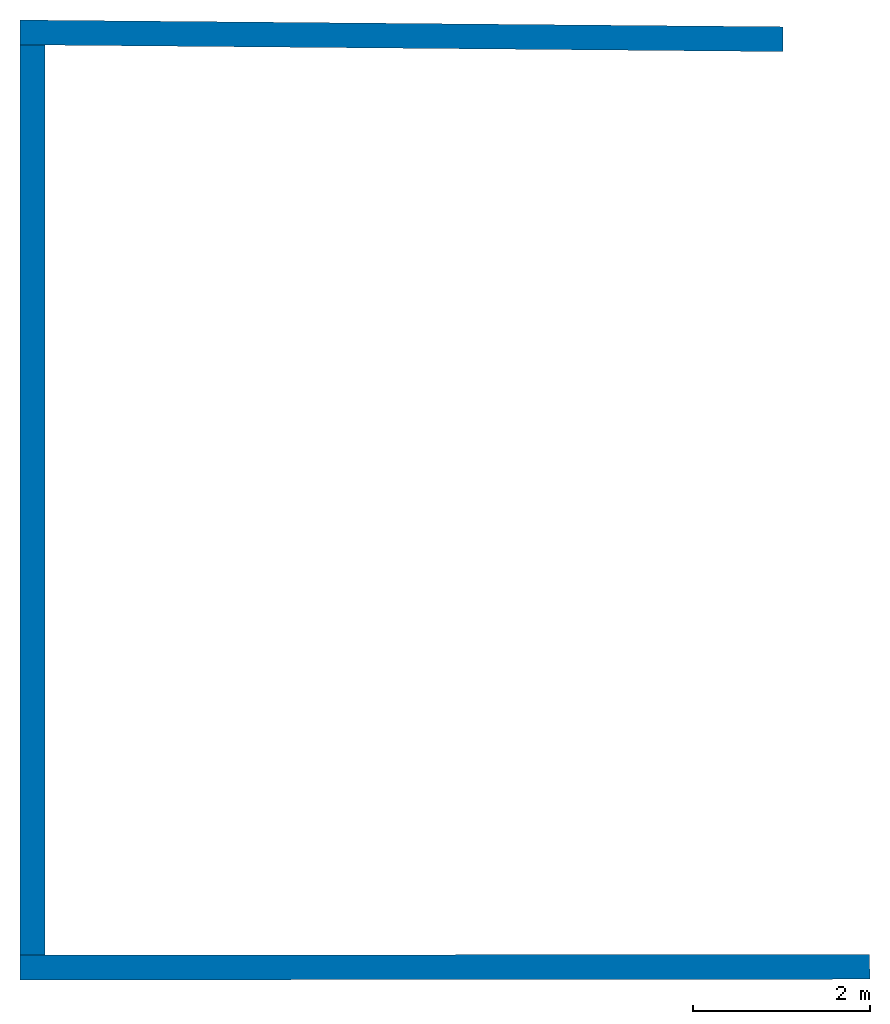
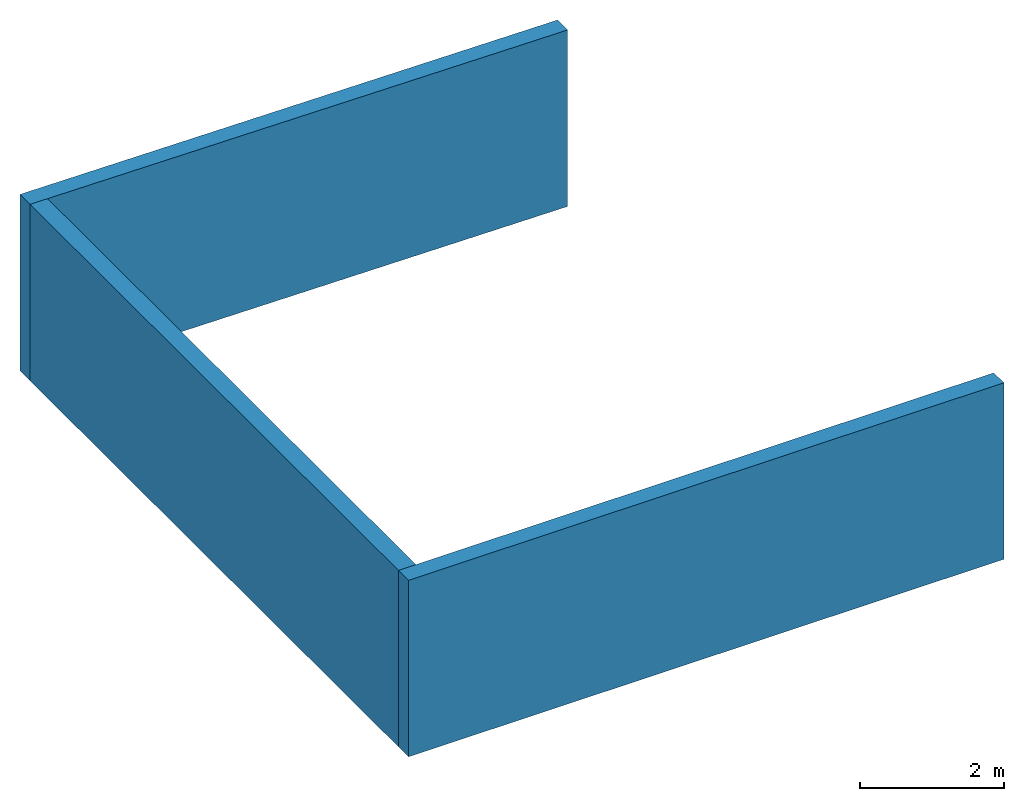
# One storey: 3 walls.
"""IFC4 building model written with IfcOpenShell, lengths in metres."""

from ifc_helpers import new_model, entity, si_unit, converted_unit, frame, frame_2d, origin_with_axes, place, context, subcontext, project, spatial, indexed_curve, outline, extrude, clip, halfspace, material, layer, layer_set, layer_usage, type_object, element, save


model = new_model("IFC4")

# Units and contexts
model_context = context("Model", 3, precision=1e-05, world=origin_with_axes())
plan_context = context("Plan", 2, precision=1e-05, world=frame_2d((0.0, 0.0, 0.0), x_axis=(1.0, 0.0, 0.0)))
body_context = subcontext(model_context, "Body", "Model", "MODEL_VIEW")
ifc_project = project(units=[converted_unit("PLANEANGLEUNIT", "degree", entity("IfcReal", 0.0174532925199433), si_unit("PLANEANGLEUNIT", "RADIAN"), dimensions=[0, 0, 0, 0, 0, 0, 0]), si_unit("AREAUNIT", "SQUARE_METRE"), si_unit("VOLUMEUNIT", "CUBIC_METRE"), si_unit("LENGTHUNIT", "METRE")], contexts=[model_context, plan_context])

# Site, building, storey
site_placement = place(None, origin_with_axes())
site = spatial("IfcSite", under=ifc_project, at=site_placement)
building_placement = place(site_placement, origin_with_axes())
building = spatial("IfcBuilding", under=site, at=building_placement, Name="Building")
storey_placement = place(building_placement, origin_with_axes())
storey = spatial("IfcBuildingStorey", under=building, at=storey_placement, Name="Storey")

# Walls
ifc_material = material(Name="aussenwand_280_material")
ifc_layer = layer(ifc_material, 0.280000001192093)
ifc_layer_set = layer_set([ifc_layer])
ifc_layer_usage_1 = layer_usage(ifc_layer_set, "AXIS2", "POSITIVE", 0.0)
wall_type = type_object("IfcWallType", Name="aussenwand_280", PredefinedType="STANDARD", material=ifc_layer_set)
wall_1_placement = place(storey_placement, frame((9.47131252288818, 11.6613798141479, 0.0), z_axis=(0.0, 0.0, 1.0), x_axis=(-0.999960541725159, 0.00888374913483858, 0.0)))
element("IfcWall", 1, at=wall_1_placement, inside=storey, type_object=wall_type, material=ifc_layer_usage_1, Name="Wall", PredefinedType="NOTDEFINED", context=body_context, shape_type="Clipping", body=[
    clip(clip(extrude(outline(indexed_curve([(0.0, 0.0), (0.0, 0.280000001192093), (8.87914620865895, 0.280000001192093), (8.87914620865895, 0.0), (0.0, 0.0)], self_intersect=False)), origin_with_axes(), (0.0, 0.0, 1.0), 3.0), halfspace(frame((0.282497853040695, 4.32133674621582e-07, 0.0), z_axis=(-0.839997529983521, -0.00746262166649103, 0.0), x_axis=(-0.0024875404778868, 0.279999166727066, 0.0)), False)), halfspace(frame((8.87914562225342, 4.97326254844666e-07, 0.0), z_axis=(0.839997529983521, 0.00746244285255671, 0.0), x_axis=(-0.00248748087324202, 0.279999166727066, 0.0)), False)),
])
ifc_layer_usage_2 = layer_usage(ifc_layer_set, "AXIS2", "POSITIVE", 0.0)
wall_2_placement = place(storey_placement, frame((0.592516601085663, 0.922550857067108, 0.0), z_axis=(0.0, 0.0, 1.0), x_axis=(0.999999582767487, 0.000923240790143609, 0.0)))
element("IfcWall", 2, at=wall_2_placement, inside=storey, type_object=wall_type, material=ifc_layer_usage_2, Name="Wall", PredefinedType="NOTDEFINED", context=body_context, shape_type="Clipping", body=[
    clip(clip(extrude(outline(indexed_curve([(0.0, 0.0), (0.0, 0.280000001192093), (17.7553288631672, 0.280000001192093), (17.7553288631672, 0.0), (0.0, 0.0)], self_intersect=False)), origin_with_axes(), (0.0, 0.0, 1.0), 3.0), halfspace(frame((-1.38534232974052e-08, -4.3713953346014e-08, 0.0), z_axis=(-0.839999914169312, 0.000775522494222969, 0.0), x_axis=(0.000258507498074323, 0.279999971389771, 0.0)), False)), halfspace(frame((9.57749176025391, 3.81842255592346e-08, 0.0), z_axis=(0.839999616146088, 0.0143678784370422, 0.0), x_axis=(-0.00478929281234741, 0.279999852180481, 0.0)), False)),
])
ifc_layer_usage_3 = layer_usage(ifc_layer_set, "AXIS2", "POSITIVE", 0.0)
wall_3_placement = place(storey_placement, frame((0.592518389225006, 11.7402601242065, 0.0), z_axis=(0.0, 0.0, 1.0), x_axis=(-1.62920684942947e-07, -1.0, 0.0)))
element("IfcWall", 3, at=wall_3_placement, inside=storey, type_object=wall_type, material=ifc_layer_usage_3, Name="Wall", PredefinedType="NOTDEFINED", context=body_context, shape_type="Clipping", body=[
    clip(clip(extrude(outline(indexed_curve([(0.0, 0.0), (0.0, 0.280000001192093), (10.8177079023357, 0.280000001192093), (10.8177079023357, 0.0), (0.0, 0.0)], self_intersect=False)), origin_with_axes(), (0.0, 0.0, 1.0), 3.0), halfspace(frame((0.280009180307388, -1.93678033610922e-08, 0.0), z_axis=(-0.840000092983246, 0.00746141094714403, 0.0), x_axis=(0.00248713698238134, 0.280000030994415, 0.0)), False)), halfspace(frame((10.5377082824707, -1.7106486893681e-08, 0.0), z_axis=(0.840000092983246, 0.000775474065449089, 0.0), x_axis=(-0.000258491345448419, 0.280000030994415, 0.0)), False)),
])

save(model, "model.ifc")
